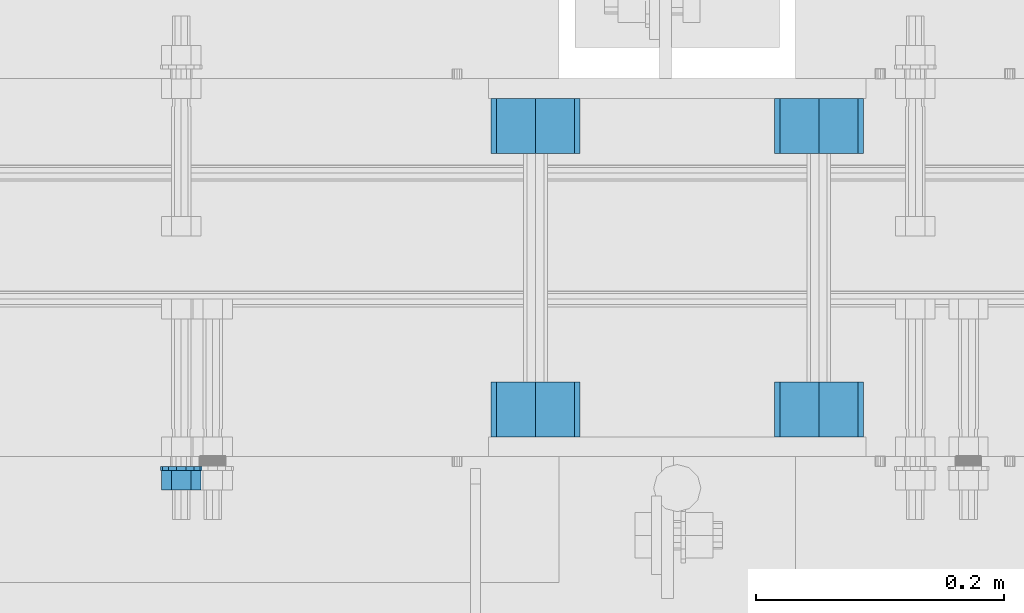
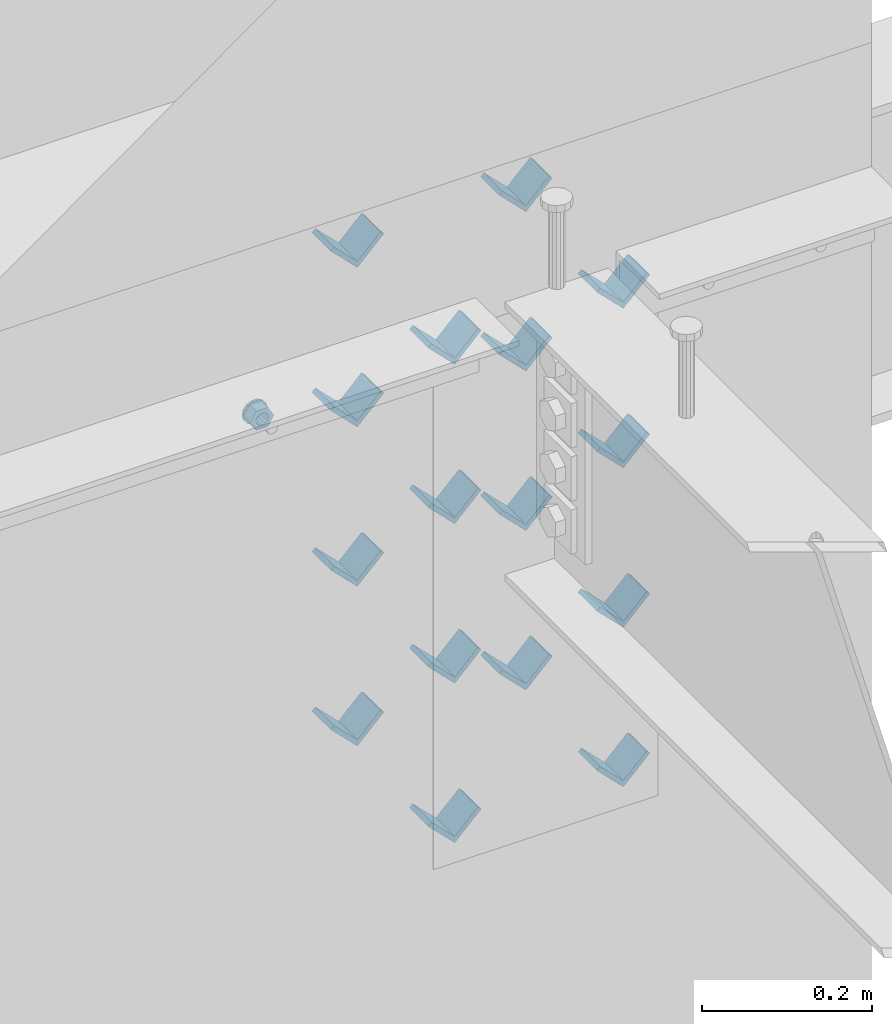
# One storey, part 625 of 975: 18 beams.
"""IFC2X3 building model written with IfcOpenShell, lengths in millimetres."""

import ifcopenshell
import ifcopenshell.guid

model = None  # the IFC model being written
_history = None  # IfcOwnerHistory: only IFC2X3 demands one
_inside = {}  # id of a spatial element -> (the spatial element, [elements in it])
_under = {}  # id of a project, library or spatial element -> (it, [spatial elements below it])
_declared = {}  # id of a project -> (the project, [libraries it declares])
_typed = {}  # id of a type object -> (the type object, [elements of that type])
_made_of = {}  # id of a material, layer set ... -> (it, [elements and type objects made of it])


def new_model(schema):
    """Start an empty IFC model of exactly this schema.

    Asked for "IFC4X3", IfcOpenShell would pick the latest addendum, in which some entities
    have other attributes; the version numbers below select the first issue.
    IFC2X3 requires an IfcOwnerHistory on every rooted entity: one is made here for all.
    """
    global model, _history
    if schema == "IFC4X3":
        model = ifcopenshell.file(schema_version=(4, 3, 0, 0))
    else:
        model = ifcopenshell.file(schema=schema)
    _inside.clear()
    _under.clear()
    _declared.clear()
    _typed.clear()
    _made_of.clear()
    _history = None
    if model.schema == "IFC2X3":
        org = make("IfcOrganization", Name="unknown")
        user = make(
            "IfcPersonAndOrganization",
            ThePerson=make("IfcPerson", FamilyName="unknown"),
            TheOrganization=org,
        )
        app = make(
            "IfcApplication",
            ApplicationDeveloper=org,
            Version="unknown",
            ApplicationFullName="unknown",
            ApplicationIdentifier="unknown",
        )
        _history = make(
            "IfcOwnerHistory",
            OwningUser=user,
            OwningApplication=app,
            ChangeAction="ADDED",
            CreationDate=0,
        )
    return model


def make(cls, **values):
    """One entity of the class cls with the attributes given. An attribute that is None is left unset."""
    return model.create_entity(
        cls, **{name: value for name, value in values.items() if value is not None}
    )


def rooted(cls, **values):
    """An entity with a GlobalId (a new one), such as an element, a storey or a relation."""
    return make(cls, GlobalId=ifcopenshell.guid.new(), OwnerHistory=_history, **values)


def si_unit(unit_type, name, prefix=None):
    """IfcSIUnit, for example si_unit("LENGTHUNIT", "METRE", prefix="MILLI")."""
    return make("IfcSIUnit", UnitType=unit_type, Prefix=prefix, Name=name)


def assignment(units):
    """IfcUnitAssignment: the units of a project."""
    return None if units is None else make("IfcUnitAssignment", Units=units)


def point(xyz):
    """IfcCartesianPoint."""
    return None if xyz is None else make("IfcCartesianPoint", Coordinates=xyz)


def direction(xyz):
    """IfcDirection."""
    return None if xyz is None else make("IfcDirection", DirectionRatios=xyz)


def frame(location, z_axis=None, x_axis=None):
    """IfcAxis2Placement3D, a coordinate frame: its origin and axes. An axis left out is left unset."""
    return make(
        "IfcAxis2Placement3D",
        Location=point(location),
        Axis=direction(z_axis),
        RefDirection=direction(x_axis),
    )


def origin_with_axes():
    """The frame at (0, 0, 0) with the z axis (0, 0, 1) and the x axis (1, 0, 0) written out."""
    return frame((0.0, 0.0, 0.0), z_axis=(0.0, 0.0, 1.0), x_axis=(1.0, 0.0, 0.0))


def place(relative_to, where):
    """IfcLocalPlacement: puts the frame where relative to a parent placement (None: the world)."""
    return make(
        "IfcLocalPlacement", PlacementRelTo=relative_to, RelativePlacement=where
    )


def context(
    kind, dimensions, precision=None, world=None, true_north=None, identifier=None
):
    """IfcGeometricRepresentationContext, for example the 3D "Model" context."""
    return make(
        "IfcGeometricRepresentationContext",
        ContextIdentifier=identifier,
        ContextType=kind,
        CoordinateSpaceDimension=dimensions,
        Precision=precision,
        WorldCoordinateSystem=world,
        TrueNorth=true_north,
    )


def subcontext(parent, identifier, kind, view, scale=None):
    """IfcGeometricRepresentationSubContext, for example "Body" below "Model"."""
    return make(
        "IfcGeometricRepresentationSubContext",
        ContextIdentifier=identifier,
        ContextType=kind,
        ParentContext=parent,
        TargetScale=scale,
        TargetView=view,
    )


def project(units=None, contexts=None):
    """IfcProject with its units and contexts."""
    return rooted(
        "IfcProject",
        Name="project",
        RepresentationContexts=contexts,
        UnitsInContext=assignment(units),
    )


def spatial(cls, under=None, at=None, **own):
    """A site, building, storey or space (cls), placed at a placement, below another one or the project."""
    s = rooted(cls, ObjectPlacement=at, **own)
    if under is not None:
        _under.setdefault(under.id(), (under, []))[1].append(s)
    return s


def faces_of(points, faces, orient=None, outer=None):
    """IfcFace entities. A face is a list of loops; a loop is a list of indices into points, from 0.

    orient and outer hold one flag for each loop. By default every Orientation is true, the
    first loop of a face is its IfcFaceOuterBound and the others are IfcFaceBound.
    """
    made = []
    for i, loops in enumerate(faces):
        bounds = []
        for j, loop in enumerate(loops):
            is_outer = j == 0 if outer is None else outer[i][j]
            bounds.append(
                make(
                    "IfcFaceOuterBound" if is_outer else "IfcFaceBound",
                    Bound=make("IfcPolyLoop", Polygon=[points[k] for k in loop]),
                    Orientation=True if orient is None else orient[i][j],
                )
            )
        made.append(make("IfcFace", Bounds=bounds))
    return made


def faceted_brep(points, faces, orient=None, outer=None, voids=None):
    """IfcFacetedBrep: a solid bounded by flat faces; with voids (closed shells), ...WithVoids."""
    shared = [point(p) for p in points]
    hull = make("IfcClosedShell", CfsFaces=faces_of(shared, faces, orient, outer))
    if voids is None:
        return make("IfcFacetedBrep", Outer=hull)
    return make(
        "IfcFacetedBrepWithVoids",
        Outer=hull,
        Voids=[
            make(cls, CfsFaces=faces_of(shared, fs, o, b)) for cls, fs, o, b in voids
        ],
    )


def shape(context_of_items, identifier, shape_type, items):
    """IfcShapeRepresentation: the items that make up one representation, for example the "Body"."""
    return make(
        "IfcShapeRepresentation",
        ContextOfItems=context_of_items,
        RepresentationIdentifier=identifier,
        RepresentationType=shape_type,
        Items=items,
    )


def material(Name=None, Category=None):
    """IfcMaterial."""
    return make("IfcMaterial", Name=Name, Category=Category)


def made_of(thing, what):
    """Note that an element or type object is made of a material, layer set ...; save() writes the relation."""
    if what is not None:
        _made_of.setdefault(what.id(), (what, []))[1].append(thing)
    return thing


def type_object(cls, material=None, **own):
    """A type object (cls), such as IfcWallType, which elements share."""
    return made_of(rooted(cls, **own), material)


def element(
    cls,
    number,
    at=None,
    inside=None,
    cuts=None,
    type_object=None,
    material=None,
    context=None,
    identifier="Body",
    shape_type=None,
    held_by="IfcProductDefinitionShape",
    body=None,
    shapes=None,
    **own,
):
    """One element of the class cls, such as IfcWall. Its Tag is "e" and its number.

    at: its placement. inside: the storey or other place that contains it. cuts: it is an
    opening in that element (IfcRelVoidsElement). A single representation is given by context,
    identifier, shape_type and body (its items); several are given by shapes. held_by: the class
    of the entity that holds the representations. save() writes the other relations.
    """
    e = rooted(cls, Tag="e%d" % number, ObjectPlacement=at, **own)
    if body is not None:
        shapes = [shape(context, identifier, shape_type, body)]
    if shapes is not None:
        e.Representation = make(held_by, Representations=shapes)
    if inside is not None:
        _inside.setdefault(inside.id(), (inside, []))[1].append(e)
    if cuts is not None:
        rooted(
            "IfcRelVoidsElement", RelatingBuildingElement=cuts, RelatedOpeningElement=e
        )
    if type_object is not None:
        _typed.setdefault(type_object.id(), (type_object, []))[1].append(e)
    return made_of(e, material)


def aggregate(whole, parts):
    """IfcRelAggregates: a whole, such as a stair, and the parts it consists of."""
    return rooted("IfcRelAggregates", RelatingObject=whole, RelatedObjects=parts)


def save(model, path):
    """Write the relations noted so far, then the file.

    IfcRelAggregates (storeys below a building ...), IfcRelContainedInSpatialStructure (elements
    in a storey), IfcRelDefinesByType, IfcRelAssociatesMaterial and IfcRelDeclares: one each for
    every whole, place, type object, material and project.
    """
    for whole, parts in _under.values():
        aggregate(whole, parts)
    for where, things in _inside.values():
        rooted(
            "IfcRelContainedInSpatialStructure",
            RelatedElements=things,
            RelatingStructure=where,
        )
    for kind, things in _typed.values():
        rooted("IfcRelDefinesByType", RelatedObjects=things, RelatingType=kind)
    for what, things in _made_of.values():
        rooted("IfcRelAssociatesMaterial", RelatedObjects=things, RelatingMaterial=what)
    for by, libraries in _declared.values():
        rooted("IfcRelDeclares", RelatingContext=by, RelatedDefinitions=libraries)
    model.write(path)


model = new_model("IFC2X3")

# Units and contexts
model_context = context("Model", 3, precision=1e-05, world=origin_with_axes())
body_context = subcontext(model_context, "Body", "Model", "MODEL_VIEW")
ifc_project = project(units=[si_unit("LENGTHUNIT", "METRE", prefix="MILLI"), si_unit("AREAUNIT", "SQUARE_METRE"), si_unit("VOLUMEUNIT", "CUBIC_METRE"), si_unit("MASSUNIT", "GRAM", prefix="KILO"), si_unit("TIMEUNIT", "SECOND"), si_unit("PLANEANGLEUNIT", "RADIAN"), si_unit("SOLIDANGLEUNIT", "STERADIAN"), si_unit("THERMODYNAMICTEMPERATUREUNIT", "DEGREE_CELSIUS"), si_unit("LUMINOUSINTENSITYUNIT", "LUMEN")], contexts=[model_context])

# Site, building, storey
site_placement = place(None, origin_with_axes())
site = spatial("IfcSite", under=ifc_project, at=site_placement, CompositionType="ELEMENT")
building_placement = place(site_placement, origin_with_axes())
building = spatial("IfcBuilding", under=site, at=building_placement, Name="Undefined", CompositionType="ELEMENT")
storey_placement = place(building_placement, origin_with_axes())
storey = spatial("IfcBuildingStorey", under=building, at=storey_placement, Name="Undefined", CompositionType="ELEMENT", Elevation=0.0)

# Beams
ifc_material = material(Name="STEEL/A36")
beam_type_1 = type_object("IfcBeamType", Name="L2X2X1/4", PredefinedType="NOTDEFINED")
for number, where, z_axis, x_axis, name in (
    (1, (13373.1004190094, 20459.6337290899, 3417.06996517217), (-0.707106781186557, 0.0, 0.707106781186538), (0.0, 1.0, 0.0), "ANGLE"),
    (2, (13601.7004190094, 20459.6337290899, 3417.06996517217), (-0.707106781186557, 0.0, 0.707106781186538), (0.0, 1.0, 0.0), "ANGLE"),
    (3, (13373.1004190094, 20688.3662709101, 3417.06996517217), (-0.707106781186557, 0.0, 0.707106781186538), (0.0, 1.0, 0.0), "ANGLE"),
    (4, (13601.7004190094, 20688.3662709101, 3417.06996517217), (-0.707106781186557, 0.0, 0.707106781186538), (0.0, 1.0, 0.0), "ANGLE"),
    (5, (13373.1004190094, 20459.6337290899, 3645.66996517217), (-0.707106781186557, 0.0, 0.707106781186538), (0.0, 1.0, 0.0), "ANGLE"),
    (6, (13601.7004190094, 20459.6337290899, 3645.66996517217), (-0.707106781186557, 0.0, 0.707106781186538), (0.0, 1.0, 0.0), "ANGLE"),
    (7, (13373.1004190094, 20688.3662709101, 3645.66996517217), (-0.707106781186557, 0.0, 0.707106781186538), (0.0, 1.0, 0.0), "ANGLE"),
    (8, (13601.7004190094, 20688.3662709101, 3645.66996517217), (-0.707106781186557, 0.0, 0.707106781186538), (0.0, 1.0, 0.0), "ANGLE"),
    (9, (13373.1004190083, 20459.6337290899, 3188.4699651707), (-0.707106781186557, 0.0, 0.707106781186538), (0.0, 1.0, 0.0), "ANGLE"),
    (10, (13373.1004190094, 20459.6337290899, 3874.26996517217), (-0.707106781186557, 0.0, 0.707106781186538), (0.0, 1.0, 0.0), "ANGLE"),
    (11, (13601.7004190083, 20459.6337290899, 3188.4699651707), (-0.707106781186557, 0.0, 0.707106781186538), (0.0, 1.0, 0.0), "ANGLE"),
    (12, (13601.7004190094, 20459.6337290899, 3874.26996517217), (-0.707106781186557, 0.0, 0.707106781186538), (0.0, 1.0, 0.0), "ANGLE"),
    (13, (13373.1004190083, 20688.3662709101, 3188.4699651707), (-0.707106781186557, 0.0, 0.707106781186538), (0.0, 1.0, 0.0), "ANGLE"),
    (14, (13373.1004190094, 20688.3662709101, 3874.26996517217), (-0.707106781186557, 0.0, 0.707106781186538), (0.0, 1.0, 0.0), "ANGLE"),
    (15, (13601.7004190083, 20688.3662709101, 3188.4699651707), (-0.707106781186557, 0.0, 0.707106781186538), (0.0, 1.0, 0.0), "ANGLE"),
    (16, (13601.7004190094, 20688.3662709101, 3874.26996517217), (-0.707106781186557, 0.0, 0.707106781186538), (0.0, 1.0, 0.0), "ANGLE"),
):
    element("IfcBeam", number, at=place(storey_placement, frame(where, z_axis=z_axis, x_axis=x_axis)), inside=storey, type_object=beam_type_1, material=ifc_material, Name=name, ObjectType="L2X2X1/4", context=body_context, shape_type="Brep", body=[
        faceted_brep([(0.0, 25.3999999999724, -25.4000000000342), (0.0, 25.400000000016, 25.4000000000196), (44.4499999999971, 25.4000000000033, 25.4000000000051), (44.4499999999971, 25.4000000000033, -25.4000000000024), (3.27418092638254e-11, 19.0500000000002, 25.4000000000269), (44.4499999999971, 19.0500000000011, 25.400000000006), (-2.5465851649642e-11, 19.0500000000002, -19.0500000000211), (44.4499999999971, 19.0500000000011, -19.050000000002), (-2.5465851649642e-11, -25.3999999999996, -19.0500000000211), (44.4499999999971, -25.4000000000069, -19.0500000000038), (0.0, -25.400000000016, -25.4000000000196), (44.4499999999971, -25.4000000000069, -25.4000000000033)], [[[0, 1, 2, 3]], [[1, 4, 5, 2]], [[4, 6, 7, 5]], [[6, 8, 9, 7]], [[8, 10, 11, 9]], [[10, 0, 3, 11]], [[5, 7, 9, 11, 3, 2]], [[10, 8, 6, 4, 1, 0]]]),
    ])
beam_type_2 = type_object("IfcBeamType", Name="5/8_HEAVY_HEX_NUT", PredefinedType="NOTDEFINED")
beam_1_placement = place(storey_placement, frame((13087.3500244105, 20416.8375, 3886.2), z_axis=(0.0, 0.0, 1.0), x_axis=(0.0, 1.0, 0.0)))
element("IfcBeam", 17, at=beam_1_placement, inside=storey, type_object=beam_type_2, material=ifc_material, Name="NUT", ObjectType="5/8_HEAVY_HEX_NUT", context=body_context, shape_type="Brep", body=[
    faceted_brep([(-1.09139364212751e-11, -15.8800001144436, -2.72848410531878e-12), (1.45519152283669e-11, -7.94000005722046, -13.7500000000036), (15.8750000000146, -7.94000005722137, -13.7500000000045), (15.8749999999891, -15.8800001144446, -2.72848410531878e-12), (2.91038304567337e-11, 7.94000005722319, -13.7500000000027), (15.8750000000291, 7.94000005722319, -13.7500000000027), (2.18278728425503e-11, 15.8800001144436, 9.09494701772928e-13), (15.8750000000218, 15.8800001144427, 9.09494701772928e-13), (-7.27595761418343e-12, 7.94000005722046, 13.7500000000027), (15.8749999999927, 7.94000005722046, 13.7500000000027), (-2.18278728425503e-11, -7.94000005722228, 13.7500000000009), (15.8749999999782, -7.94000005722319, 13.7500000000009), (-7.27595761418343e-12, 0.0, 8.72999954223724), (0.0, 3.78780484388062, 7.86545780435881), (15.875, 3.78780484387971, 7.86545780435881), (15.8749999999927, -9.09494701772928e-13, 8.72999954223724), (7.27595761418343e-12, 6.82538848405238, 5.44306568481716), (15.8750000000073, 6.82538848405238, 5.44306568481716), (1.09139364212751e-11, 8.51112022706275, 1.94260765157742), (15.8750000000109, 8.51112022706093, 1.94260765157651), (1.45519152283669e-11, 8.51112022706184, -1.94260765157651), (15.8750000000146, 8.51112022706184, -1.94260765157651), (2.18278728425503e-11, 6.8253884840542, -5.44306568481716), (15.8750000000218, 6.82538848405238, -5.44306568481716), (1.81898940354586e-11, 3.78780484388153, -7.86545780435881), (15.8750000000182, 3.78780484388062, -7.86545780435881), (1.81898940354586e-11, 9.09494701772928e-13, -8.72999954223997), (15.8750000000182, 9.09494701772928e-13, -8.72999954223997), (1.09139364212751e-11, -3.78780484387971, -7.86545780436063), (15.8750000000109, -3.78780484388062, -7.86545780436063), (3.63797880709171e-12, -6.82538848405238, -5.44306568481807), (15.8750000000036, -6.82538848405329, -5.44306568481807), (0.0, -8.51112022706184, -1.94260765157833), (15.875, -8.51112022706184, -1.94260765157833), (-7.27595761418343e-12, -8.51112022706184, 1.9426076515756), (15.8749999999927, -8.51112022706275, 1.9426076515756), (-1.09139364212751e-11, -6.82538848405329, 5.44306568481534), (15.8749999999927, -6.8253884840542, 5.44306568481534), (-7.27595761418343e-12, -3.78780484388062, 7.8654578043579), (15.8749999999927, -3.78780484388153, 7.8654578043579)], [[[0, 1, 2, 3]], [[1, 4, 5, 2]], [[4, 6, 7, 5]], [[6, 8, 9, 7]], [[8, 10, 11, 9]], [[10, 0, 3, 11]], [[12, 13, 14, 15]], [[13, 16, 17, 14]], [[16, 18, 19, 17]], [[18, 20, 21, 19]], [[20, 22, 23, 21]], [[22, 24, 25, 23]], [[24, 26, 27, 25]], [[26, 28, 29, 27]], [[28, 30, 31, 29]], [[30, 32, 33, 31]], [[32, 34, 35, 33]], [[34, 36, 37, 35]], [[36, 38, 39, 37]], [[38, 12, 15, 39]], [[5, 7, 9, 11, 3, 2], [17, 19, 21, 23, 25, 27, 29, 31, 33, 35, 37, 39, 15, 14]], [[10, 8, 6, 4, 1, 0], [38, 36, 34, 32, 30, 28, 26, 24, 22, 20, 18, 16, 13, 12]]]),
])
beam_type_3 = type_object("IfcBeamType", Name="5/8_WASHER", PredefinedType="NOTDEFINED")
beam_2_placement = place(storey_placement, frame((13087.3500244105, 20432.7125, 3886.2), z_axis=(0.0, 0.0, 1.0), x_axis=(0.0, 1.0, 0.0)))
element("IfcBeam", 18, at=beam_2_placement, inside=storey, type_object=beam_type_3, material=ifc_material, Name="WASHER", ObjectType="5/8_WASHER", context=body_context, shape_type="Brep", body=[
    faceted_brep([(1.09139364212751e-11, -16.670000076293, -2.72848410531878e-12), (2.18278728425503e-11, -15.0191510966704, -7.23284196419536), (3.1750000000211, -15.0191510966711, -7.23284196419627), (3.17500000001019, -16.6700000762937, -1.81898940354586e-12), (2.91038304567337e-11, -10.3935750445523, -13.0331308723944), (3.17500000002838, -10.3935750445526, -13.0331308723953), (2.91038304567337e-11, -3.70942398602756, -16.2520483704566), (3.17500000002838, -3.70942398602779, -16.2520483704566), (2.5465851649642e-11, 3.70942398602961, -16.2520483704557), (3.17500000002474, 3.70942398602961, -16.2520483704566), (1.45519152283669e-11, 10.3935750445542, -13.0331308723935), (3.17500000001382, 10.3935750445537, -13.0331308723944), (0.0, 15.0191510966717, -7.23284196419354), (3.17499999999927, 15.0191510966713, -7.23284196419354), (-7.27595761418343e-12, 16.6700000762933, 0.0), (3.174999999992, 16.6700000762928, -9.09494701772928e-13), (-1.81898940354586e-11, 15.0191510966706, 7.23284196419354), (3.17499999998108, 15.0191510966704, 7.23284196419354), (-2.5465851649642e-11, 10.3935750445519, 13.0331308723926), (3.17499999997381, 10.3935750445517, 13.0331308723926), (-2.5465851649642e-11, 3.70942398602733, 16.2520483704538), (3.17499999997381, 3.7094239860271, 16.2520483704529), (-2.18278728425503e-11, -3.70942398602983, 16.2520483704529), (3.17499999997744, -3.70942398603006, 16.2520483704538), (-1.09139364212751e-11, -10.3935750445542, 13.0331308723908), (3.17499999998836, -10.3935750445544, 13.0331308723908), (0.0, -15.0191510966717, 7.23284196419172), (3.17499999999927, -15.019151096672, 7.23284196419081), (-7.27595761418343e-12, 0.0, 8.72999954223724), (0.0, 3.78780484388062, 7.86545780435881), (3.17499999998472, 3.78780484387903, 7.86545780435699), (3.17499999998836, -9.09494701772928e-13, 8.72999954223542), (7.27595761418343e-12, 6.82538848405238, 5.44306568481716), (3.17499999998836, 6.82538848405102, 5.44306568481534), (1.09139364212751e-11, 8.51112022706275, 1.94260765157742), (3.174999999992, 8.51112022705979, 1.94260765157651), (1.45519152283669e-11, 8.51112022706184, -1.94260765157651), (3.17499999999563, 8.51112022706025, -1.94260765157742), (2.18278728425503e-11, 6.8253884840542, -5.44306568481716), (3.17500000000655, 6.8253884840517, -5.44306568481807), (1.81898940354586e-11, 3.78780484388153, -7.86545780435881), (3.17500000001019, 3.78780484388017, -7.86545780435972), (1.81898940354586e-11, 9.09494701772928e-13, -8.72999954223997), (3.17500000001382, 6.82121026329696e-13, -8.72999954223997), (1.09139364212751e-11, -3.78780484387971, -7.86545780436063), (3.17500000001382, -3.78780484387994, -7.86545780436063), (3.63797880709171e-12, -6.82538848405238, -5.44306568481807), (3.17500000001019, -6.82538848405147, -5.44306568481898), (0.0, -8.51112022706184, -1.94260765157833), (3.17500000001019, -8.5111202270607, -1.94260765157924), (-7.27595761418343e-12, -8.51112022706184, 1.9426076515756), (3.17500000000291, -8.51112022706093, 1.94260765157469), (-1.09139364212751e-11, -6.82538848405329, 5.44306568481534), (3.17499999999563, -6.82538848405238, 5.44306568481534), (-7.27595761418343e-12, -3.78780484388062, 7.8654578043579), (3.174999999992, -3.78780484388085, 7.86545780435699)], [[[0, 1, 2, 3]], [[1, 4, 5, 2]], [[4, 6, 7, 5]], [[6, 8, 9, 7]], [[8, 10, 11, 9]], [[10, 12, 13, 11]], [[12, 14, 15, 13]], [[14, 16, 17, 15]], [[16, 18, 19, 17]], [[18, 20, 21, 19]], [[20, 22, 23, 21]], [[22, 24, 25, 23]], [[24, 26, 27, 25]], [[26, 0, 3, 27]], [[28, 29, 30, 31]], [[29, 32, 33, 30]], [[32, 34, 35, 33]], [[34, 36, 37, 35]], [[36, 38, 39, 37]], [[38, 40, 41, 39]], [[40, 42, 43, 41]], [[42, 44, 45, 43]], [[44, 46, 47, 45]], [[46, 48, 49, 47]], [[48, 50, 51, 49]], [[50, 52, 53, 51]], [[52, 54, 55, 53]], [[54, 28, 31, 55]], [[5, 7, 9, 11, 13, 15, 17, 19, 21, 23, 25, 27, 3, 2], [33, 35, 37, 39, 41, 43, 45, 47, 49, 51, 53, 55, 31, 30]], [[26, 24, 22, 20, 18, 16, 14, 12, 10, 8, 6, 4, 1, 0], [54, 52, 50, 48, 46, 44, 42, 40, 38, 36, 34, 32, 29, 28]]]),
])

save(model, "model.ifc")
